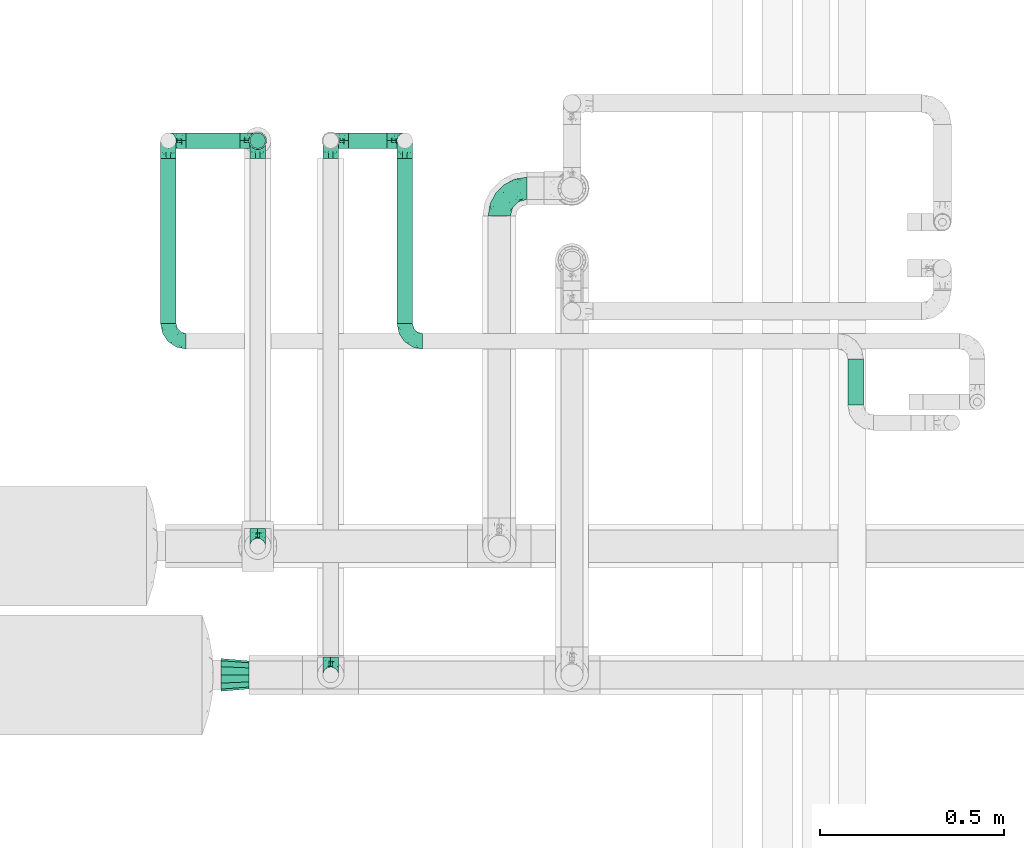
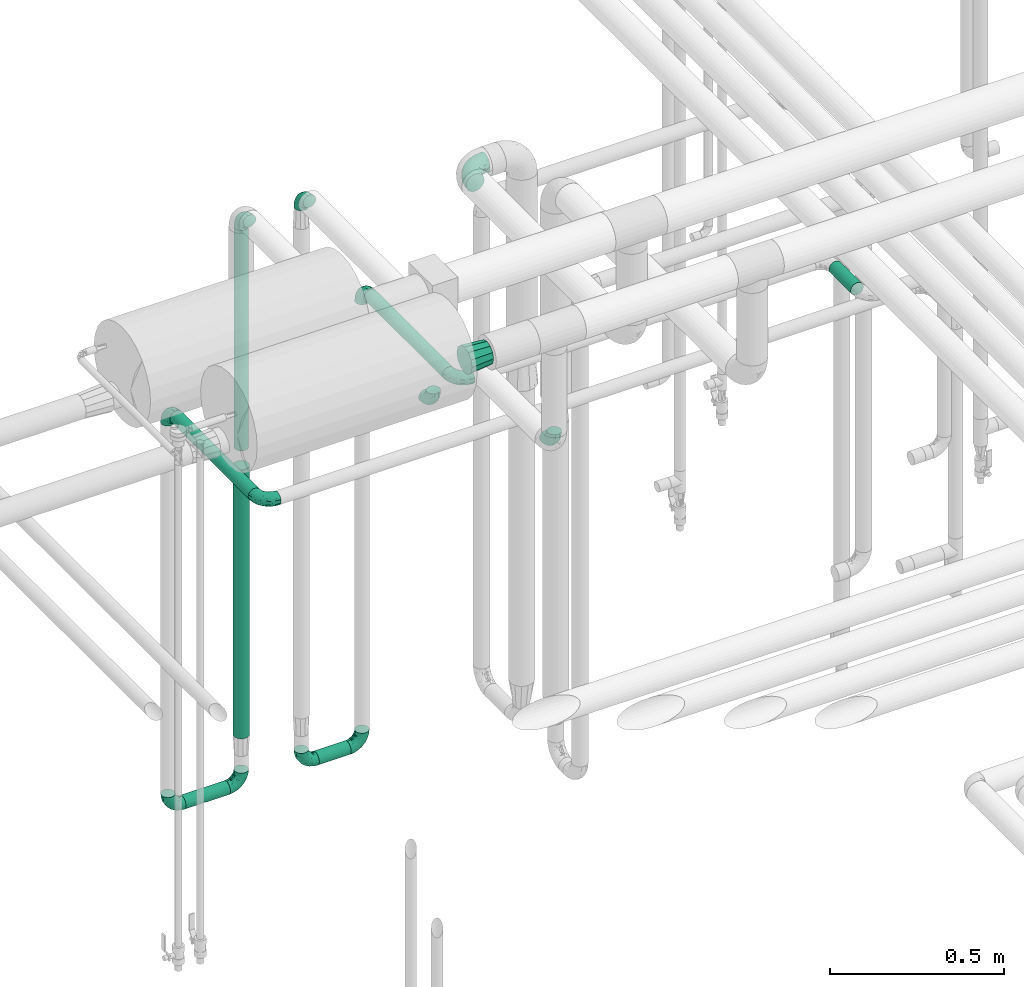
# One storey, part 573 of 827: 14 flow fittings, 7 flow segments.
"""IFC2X3 building model written with IfcOpenShell, lengths in millimetres."""

from ifc_helpers import new_model, entity, si_unit, converted_unit, derived_unit, direction, frame, origin, origin_2d_with_axis, place, context, subcontext, project, spatial, circle, extrude, faceted_brep, source, transform, mapped, material, type_object, type_shapes, element, save


model = new_model("IFC2X3")

# Units and contexts
model_context = context("Model", 3, precision=0.01, world=origin(), true_north=direction((6.12303176911189e-17, 1.0)))
body_context = subcontext(model_context, "Body", "Model", "MODEL_VIEW")
ifc_project = project(units=[si_unit("LENGTHUNIT", "METRE", prefix="MILLI"), si_unit("AREAUNIT", "SQUARE_METRE"), si_unit("VOLUMEUNIT", "CUBIC_METRE"), converted_unit("PLANEANGLEUNIT", "DEGREE", entity("IfcRatioMeasure", 0.0174532925199433), si_unit("PLANEANGLEUNIT", "RADIAN"), dimensions=[0, 0, 0, 0, 0, 0, 0]), si_unit("MASSUNIT", "GRAM", prefix="KILO"), derived_unit("MASSDENSITYUNIT", [(si_unit("MASSUNIT", "GRAM", prefix="KILO"), 1), (si_unit("LENGTHUNIT", "METRE"), -3)]), derived_unit("MOMENTOFINERTIAUNIT", [(si_unit("LENGTHUNIT", "METRE"), 4)]), si_unit("TIMEUNIT", "SECOND"), si_unit("FREQUENCYUNIT", "HERTZ"), si_unit("THERMODYNAMICTEMPERATUREUNIT", "DEGREE_CELSIUS"), derived_unit("THERMALTRANSMITTANCEUNIT", [(si_unit("MASSUNIT", "GRAM", prefix="KILO"), 1), (si_unit("THERMODYNAMICTEMPERATUREUNIT", "KELVIN"), -1), (si_unit("TIMEUNIT", "SECOND"), -3)]), derived_unit("VOLUMETRICFLOWRATEUNIT", [(si_unit("LENGTHUNIT", "METRE"), 3), (si_unit("TIMEUNIT", "SECOND"), -1)]), derived_unit("MASSFLOWRATEUNIT", [(si_unit("MASSUNIT", "GRAM", prefix="KILO"), 1), (si_unit("TIMEUNIT", "SECOND"), -1)]), derived_unit("ROTATIONALFREQUENCYUNIT", [(si_unit("TIMEUNIT", "SECOND"), -1)]), si_unit("ELECTRICCURRENTUNIT", "AMPERE"), si_unit("ELECTRICVOLTAGEUNIT", "VOLT"), si_unit("POWERUNIT", "WATT"), si_unit("FORCEUNIT", "NEWTON", prefix="KILO"), si_unit("ILLUMINANCEUNIT", "LUX"), si_unit("LUMINOUSFLUXUNIT", "LUMEN"), si_unit("LUMINOUSINTENSITYUNIT", "CANDELA"), derived_unit("USERDEFINED", [(si_unit("MASSUNIT", "GRAM", prefix="KILO"), -1), (si_unit("LENGTHUNIT", "METRE"), -2), (si_unit("TIMEUNIT", "SECOND"), 3), (si_unit("LUMINOUSFLUXUNIT", "LUMEN"), 1)]), derived_unit("LINEARVELOCITYUNIT", [(si_unit("LENGTHUNIT", "METRE"), 1), (si_unit("TIMEUNIT", "SECOND"), -1)]), si_unit("PRESSUREUNIT", "PASCAL"), derived_unit("USERDEFINED", [(si_unit("LENGTHUNIT", "METRE"), -2), (si_unit("MASSUNIT", "GRAM", prefix="KILO"), 1), (si_unit("TIMEUNIT", "SECOND"), -2)]), derived_unit("LINEARFORCEUNIT", [(si_unit("MASSUNIT", "GRAM", prefix="KILO"), 1), (si_unit("LENGTHUNIT", "METRE"), 1), (si_unit("TIMEUNIT", "SECOND"), -2), (si_unit("LENGTHUNIT", "METRE"), -1)]), derived_unit("PLANARFORCEUNIT", [(si_unit("MASSUNIT", "GRAM", prefix="KILO"), 1), (si_unit("LENGTHUNIT", "METRE"), 1), (si_unit("TIMEUNIT", "SECOND"), -2), (si_unit("LENGTHUNIT", "METRE"), -2)])], contexts=[model_context])

# Site, building, storey
site_placement = place(None, origin())
site = spatial("IfcSite", under=ifc_project, at=site_placement, CompositionType="ELEMENT")
building_placement = place(site_placement, origin())
building = spatial("IfcBuilding", under=site, at=building_placement, CompositionType="ELEMENT")
storey_placement = place(building_placement, frame((0.0, 0.0, 28200.0)))
storey = spatial("IfcBuildingStorey", under=building, at=storey_placement, Name="08", CompositionType="ELEMENT", Elevation=28200.0)

# Flow segments
pipe_segment_type = type_object("IfcPipeSegmentType", PredefinedType="NOTDEFINED")
flow_segment_1_placement = place(storey_placement, frame((17314.71, 15829.04, 381.11)))
element("IfcFlowSegment", 1, at=flow_segment_1_placement, inside=storey, type_object=pipe_segment_type, context=body_context, shape_type="SweptSolid", body=[
    extrude(circle(Radius=21.15, at=origin_2d_with_axis()), frame((0.0, 22.75, 22.75), z_axis=(1.0, 0.0, 0.0), x_axis=(0.0, -1.0, 0.0)), (0.0, 0.0, 1.0), 105.488840849872),
])
flow_segment_2_placement = place(storey_placement, frame((16873.63, 15829.04, 381.19)))
element("IfcFlowSegment", 2, at=flow_segment_2_placement, inside=storey, type_object=pipe_segment_type, context=body_context, shape_type="SweptSolid", body=[
    extrude(circle(Radius=21.15, at=origin_2d_with_axis()), frame((0.0, 22.75, 22.75), z_axis=(1.0, 0.0, 0.0), x_axis=(0.0, -1.0, 0.0)), (0.0, 0.0, 1.0), 146.73003738029),
])
flow_segment_3_placement = place(storey_placement, frame((18670.46, 15133.74, 1977.25)))
element("IfcFlowSegment", 3, at=flow_segment_3_placement, inside=storey, type_object=pipe_segment_type, context=body_context, shape_type="SweptSolid", body=[
    extrude(circle(Radius=21.15, at=origin_2d_with_axis()), frame((22.75, 0.0, 22.75), z_axis=(0.0, 1.0, 0.0), x_axis=(-1.0, 0.0, 0.0)), (0.0, 0.0, 1.0), 125.041289846792),
])
flow_segment_4_placement = place(storey_placement, frame((17045.62, 15829.04, 1580.0)))
element("IfcFlowSegment", 4, at=flow_segment_4_placement, inside=storey, type_object=pipe_segment_type, context=body_context, shape_type="SweptSolid", body=[
    extrude(circle(Radius=21.15, at=origin_2d_with_axis()), frame((22.75, 22.75, 0.0)), (0.0, 0.0, 1.0), 772.000000000002),
])
flow_segment_5_placement = place(storey_placement, frame((17042.77, 15826.19, 574.2)))
element("IfcFlowSegment", 5, at=flow_segment_5_placement, inside=storey, type_object=pipe_segment_type, context=body_context, shape_type="SweptSolid", body=[
    extrude(circle(Radius=24.0, at=origin_2d_with_axis()), frame((25.6, 25.6, 0.0)), (0.0, 0.0, 1.0), 941.79999999999),
])
flow_segment_6_placement = place(storey_placement, frame((17445.46, 15354.79, 1977.25)))
element("IfcFlowSegment", 6, at=flow_segment_6_placement, inside=storey, type_object=pipe_segment_type, context=body_context, shape_type="SweptSolid", body=[
    extrude(circle(Radius=21.15, at=origin_2d_with_axis()), frame((22.75, 0.0, 22.75), z_axis=(0.0, 1.0, 0.0), x_axis=(1.0, 0.0, 0.0)), (0.0, 0.0, 1.0), 448.999348960777),
])
flow_segment_7_placement = place(storey_placement, frame((16802.89, 15354.79, 1777.25)))
element("IfcFlowSegment", 7, at=flow_segment_7_placement, inside=storey, type_object=pipe_segment_type, context=body_context, shape_type="SweptSolid", body=[
    extrude(circle(Radius=21.15, at=origin_2d_with_axis()), frame((22.75, 0.0, 22.75), z_axis=(0.0, 1.0, 0.0), x_axis=(1.0, 0.0, 0.0)), (0.0, 0.0, 1.0), 448.999348960775),
])

# Flow fittings
ifc_material = material()
pipe_fitting_type_1 = type_object("IfcPipeFittingType", Name="ADSK_1", PredefinedType="NOTDEFINED", material=ifc_material)
shared_shape_1 = source(origin(), body_context, "Body", "Brep", [
    faceted_brep([(-48.0, 10.6, -18.36), (-48.0, 5.49, -20.48), (-48.0, 0.0, -21.2), (-48.0, -5.49, -20.48), (-48.0, -10.6, -18.36), (-48.0, -14.99, -14.99), (-48.0, -18.36, -10.6), (-48.0, -20.48, -5.49), (-48.0, -21.2, 0.0), (-48.0, -20.48, 5.49), (-48.0, -18.36, 10.6), (-48.0, -14.99, 14.99), (-48.0, -10.6, 18.36), (-48.0, -5.49, 20.48), (-48.0, 0.0, 21.2), (-48.0, 5.49, 20.48), (-48.0, 10.6, 18.36), (-48.0, 14.99, 14.99), (-48.0, 18.36, 10.6), (-48.0, 20.48, 5.49), (-48.0, 21.2, 0.0), (-48.0, 20.48, -5.49), (-48.0, 18.36, -10.6), (-48.0, 14.99, -14.99), (0.0, 48.0, -21.2), (-5.49, 48.0, -20.48), (-10.6, 48.0, -18.36), (-14.99, 48.0, -14.99), (-18.36, 48.0, -10.6), (-20.48, 48.0, -5.49), (-21.2, 48.0, 0.0), (-20.48, 48.0, 5.49), (-18.36, 48.0, 10.6), (-14.99, 48.0, 14.99), (-10.6, 48.0, 18.36), (-5.49, 48.0, 20.48), (0.0, 48.0, 21.2), (5.49, 48.0, 20.48), (10.6, 48.0, 18.36), (14.99, 48.0, 14.99), (18.36, 48.0, 10.6), (20.48, 48.0, 5.49), (21.2, 48.0, 0.0), (20.48, 48.0, -5.49), (18.36, 48.0, -10.6), (14.99, 48.0, -14.99), (10.6, 48.0, -18.36), (5.49, 48.0, -20.48), (-35.25, -16.22, 12.01), (-34.76, -18.57, 0.0), (-20.87, -12.37, 10.9), (-31.49, -11.78, 15.9), (-37.0, -2.58, 20.86), (-33.89, 3.62, 21.15), (-31.81, -18.14, 6.76), (-5.78, 5.78, 17.67), (-19.42, -4.1, 17.86), (-9.6, -3.39, 13.73), (-35.44, -7.73, 19.13), (11.78, 31.49, 15.9), (-5.93, -5.46, 6.95), (-18.45, -13.78, 5.46), (-10.29, -8.43, 0.0), (-24.6, 0.55, 20.62), (-37.28, 17.94, 13.81), (-33.38, 22.85, 9.59), (-41.46, 20.06, 8.75), (-29.51, 20.45, 15.16), (-15.04, 10.79, 21.13), (-7.08, 16.98, 20.93), (-8.39, 23.51, 21.15), (-40.86, 13.03, 17.26), (-8.05, 41.26, 19.83), (-3.21, 35.97, 21.14), (8.53, 19.66, 14.74), (4.1, 19.42, 17.86), (-37.72, 22.66, 4.78), (-37.07, 8.58, 19.98), (-13.0, 5.43, 19.97), (-3.78, 13.93, 19.7), (3.02, 8.69, 13.43), (-2.27, -0.05, 10.65), (6.22, 6.99, 7.09), (-22.25, 34.6, 9.45), (18.14, 31.81, 6.76), (16.22, 35.25, 12.01), (12.37, 20.87, 10.9), (7.73, 35.44, 19.13), (-21.52, -15.93, 0.0), (2.58, 37.0, 20.86), (18.57, 34.76, 0.0), (13.78, 18.45, 5.46), (15.93, 21.52, 0.0), (-20.03, -8.54, 14.9), (-28.6, 28.6, 5.16), (-24.79, 34.6, 0.0), (-34.6, 24.79, 0.0), (-22.81, 37.41, 4.68), (-23.36, 26.33, 14.79), (-13.68, 37.05, 17.49), (-17.72, 38.12, 13.73), (-26.25, 27.3, 11.24), (-9.71, 32.34, 20.14), (-17.26, 25.6, 18.71), (-26.33, 9.99, 20.77), (-24.06, 6.05, 21.2), (-25.02, 15.46, 19.56), (-24.3, 20.72, 17.57), (-31.95, 15.23, 17.8), (-13.53, 24.7, 20.21), (-17.6, 17.6, 20.6), (-0.55, 24.6, 20.62), (-11.41, -7.48, 10.43), (0.93, -0.93, 0.0), (8.43, 10.29, 0.0), (-11.41, -7.48, -10.43), (-20.1, -8.84, -14.66), (-9.6, -3.39, -13.73), (7.73, 35.44, -19.13), (4.1, 19.42, -17.86), (-0.55, 24.6, -20.62), (-38.12, 17.72, -13.73), (-37.05, 13.68, -17.49), (-32.34, 9.71, -20.14), (-41.26, 8.05, -19.83), (-37.41, 22.81, -4.68), (-23.51, 8.39, -21.15), (-35.97, 3.21, -21.14), (-28.6, 28.6, -5.16), (-31.81, -18.14, -6.76), (-18.45, -13.78, -5.46), (-25.6, 17.26, -18.71), (-19.42, -4.1, -17.86), (-17.94, 37.28, -13.81), (-22.85, 33.38, -9.59), (-20.06, 41.46, -8.75), (-31.49, -11.78, -15.9), (-35.25, -16.22, -12.01), (8.53, 19.66, -14.74), (11.78, 31.49, -15.9), (-9.99, 26.33, -20.77), (-6.05, 24.06, -21.2), (-10.79, 15.04, -21.13), (-37.0, -2.58, -20.86), (-16.98, 7.08, -20.93), (-5.43, 13.0, -19.97), (-13.93, 3.78, -19.7), (-20.87, -12.37, -10.9), (-26.33, 23.36, -14.79), (-22.66, 37.72, -4.78), (13.78, 18.45, -5.46), (18.14, 31.81, -6.76), (-15.46, 25.02, -19.56), (-20.72, 24.3, -17.57), (16.22, 35.25, -12.01), (-13.03, 40.86, -17.26), (-8.58, 37.07, -19.98), (2.58, 37.0, -20.86), (-3.62, 33.89, -21.15), (-34.6, 22.25, -9.45), (6.22, 6.99, -7.09), (-20.45, 29.51, -15.16), (-35.44, -7.73, -19.13), (12.37, 20.87, -10.9), (-27.3, 26.25, -11.24), (-15.23, 31.95, -17.8), (-24.7, 13.53, -20.21), (-24.6, 0.55, -20.62), (-5.78, 5.78, -17.67), (-17.6, 17.6, -20.6), (3.02, 8.69, -13.43), (-5.93, -5.46, -6.95), (-2.27, -0.05, -10.65)], [[[0, 1, 2, 3, 4, 5, 6, 7, 8, 9, 10, 11, 12, 13, 14, 15, 16, 17, 18, 19, 20, 21, 22, 23]], [[24, 25, 26, 27, 28, 29, 30, 31, 32, 33, 34, 35, 36, 37, 38, 39, 40, 41, 42, 43, 44, 45, 46, 47]], [[10, 48, 11]], [[9, 8, 49]], [[48, 50, 51]], [[14, 52, 53]], [[10, 54, 48]], [[9, 54, 10]], [[55, 56, 57]], [[51, 12, 11]], [[51, 58, 12]], [[59, 39, 38]], [[60, 61, 62]], [[58, 56, 63]], [[64, 65, 66]], [[67, 65, 64]], [[68, 69, 70]], [[16, 71, 17]], [[13, 52, 14]], [[35, 72, 73]], [[14, 53, 15]], [[17, 64, 18]], [[74, 59, 75]], [[20, 19, 76]], [[66, 19, 18]], [[77, 15, 53]], [[15, 77, 16]], [[69, 78, 79]], [[80, 81, 82]], [[32, 31, 83]], [[84, 85, 86]], [[59, 87, 75]], [[61, 54, 88]], [[36, 89, 37]], [[84, 41, 40]], [[36, 35, 73]], [[90, 41, 84]], [[40, 39, 85]], [[12, 58, 13]], [[85, 84, 40]], [[91, 84, 86]], [[84, 92, 90]], [[87, 38, 37]], [[93, 56, 51]], [[65, 94, 76]], [[94, 95, 96]], [[84, 91, 92]], [[95, 97, 30]], [[98, 99, 100]], [[76, 94, 96]], [[101, 98, 83]], [[100, 99, 33]], [[102, 70, 73]], [[103, 102, 99]], [[94, 97, 95]], [[72, 99, 102]], [[72, 35, 34]], [[34, 33, 99]], [[9, 49, 54]], [[87, 59, 38]], [[104, 105, 68]], [[106, 103, 107]], [[106, 77, 104]], [[71, 64, 17]], [[108, 107, 67]], [[33, 32, 100]], [[109, 103, 110]], [[102, 109, 70]], [[89, 73, 111]], [[50, 48, 54]], [[51, 11, 48]], [[56, 58, 51]], [[88, 54, 49]], [[52, 58, 63]], [[50, 112, 93]], [[56, 55, 78]], [[39, 59, 85]], [[86, 85, 59]], [[89, 87, 37]], [[42, 41, 90]], [[111, 79, 75]], [[111, 75, 87]], [[75, 55, 80]], [[104, 77, 53]], [[71, 77, 108]], [[32, 83, 100]], [[98, 100, 83]], [[99, 98, 103]], [[106, 107, 108]], [[68, 70, 110]], [[111, 73, 70]], [[68, 110, 104]], [[68, 63, 78]], [[57, 93, 112]], [[80, 55, 57]], [[61, 50, 54]], [[80, 82, 86]], [[81, 57, 112]], [[74, 86, 59]], [[60, 113, 82]], [[82, 114, 91]], [[101, 94, 65]], [[97, 94, 83]], [[73, 89, 36]], [[87, 89, 111]], [[58, 52, 13]], [[53, 52, 63]], [[104, 53, 105]], [[106, 104, 110]], [[20, 76, 96]], [[76, 19, 66]], [[103, 106, 110]], [[77, 106, 108]], [[103, 98, 107]], [[67, 107, 98]], [[67, 98, 101]], [[108, 67, 64]], [[53, 63, 105]], [[63, 68, 105]], [[83, 31, 97]], [[30, 97, 31]], [[62, 113, 60]], [[112, 61, 60]], [[61, 88, 62]], [[86, 82, 91]], [[56, 78, 63]], [[114, 82, 113]], [[114, 92, 91]], [[79, 78, 55]], [[75, 79, 55]], [[69, 79, 111]], [[70, 69, 111]], [[78, 69, 68]], [[77, 71, 16]], [[64, 71, 108]], [[64, 66, 18]], [[76, 66, 65]], [[99, 72, 34]], [[73, 72, 102]], [[94, 101, 83]], [[67, 101, 65]], [[75, 80, 74]], [[80, 86, 74]], [[70, 109, 110]], [[102, 103, 109]], [[50, 93, 51]], [[57, 56, 93]], [[61, 112, 50]], [[81, 112, 60]], [[82, 81, 60]], [[80, 57, 81]], [[115, 116, 117]], [[118, 119, 120]], [[121, 122, 23]], [[123, 124, 122]], [[96, 125, 20]], [[123, 126, 127]], [[128, 96, 95]], [[129, 130, 88]], [[123, 122, 131]], [[116, 132, 117]], [[133, 134, 135]], [[0, 124, 1]], [[5, 136, 137]], [[138, 119, 139]], [[129, 88, 49]], [[140, 141, 142]], [[6, 5, 137]], [[46, 118, 47]], [[143, 3, 2]], [[144, 145, 146]], [[6, 129, 7]], [[129, 137, 147]], [[127, 2, 1]], [[148, 122, 121]], [[128, 125, 96]], [[134, 128, 149]], [[95, 149, 128]], [[150, 151, 92]], [[30, 29, 149]], [[152, 131, 153]], [[27, 133, 28]], [[154, 45, 44]], [[136, 5, 4]], [[27, 26, 155]], [[156, 26, 25]], [[24, 157, 158]], [[24, 47, 157]], [[22, 21, 159]], [[160, 150, 114]], [[134, 133, 161]], [[142, 144, 126]], [[46, 139, 118]], [[162, 136, 4]], [[156, 25, 158]], [[1, 124, 127]], [[115, 147, 116]], [[45, 154, 139]], [[139, 46, 45]], [[154, 163, 139]], [[162, 4, 3]], [[42, 90, 43]], [[130, 129, 147]], [[49, 7, 129]], [[43, 151, 44]], [[0, 23, 122]], [[24, 158, 25]], [[136, 162, 132]], [[135, 29, 28]], [[43, 90, 151]], [[164, 148, 159]], [[152, 156, 140]], [[155, 133, 27]], [[165, 153, 161]], [[23, 22, 121]], [[123, 131, 166]], [[123, 166, 126]], [[143, 127, 167]], [[147, 137, 136]], [[8, 7, 49]], [[129, 6, 137]], [[143, 162, 3]], [[167, 146, 132]], [[167, 132, 162]], [[132, 168, 117]], [[44, 151, 154]], [[92, 151, 90]], [[163, 154, 151]], [[119, 118, 139]], [[157, 118, 120]], [[138, 139, 163]], [[119, 168, 145]], [[140, 156, 158]], [[155, 156, 165]], [[22, 159, 121]], [[148, 121, 159]], [[122, 148, 131]], [[152, 153, 165]], [[142, 126, 169]], [[167, 127, 126]], [[142, 169, 140]], [[142, 120, 145]], [[168, 170, 117]], [[160, 171, 172]], [[115, 172, 171]], [[171, 62, 130]], [[119, 170, 168]], [[170, 163, 160]], [[150, 163, 151]], [[113, 171, 160]], [[164, 128, 134]], [[125, 128, 159]], [[127, 143, 2]], [[162, 143, 167]], [[118, 157, 47]], [[158, 157, 120]], [[140, 158, 141]], [[152, 140, 169]], [[30, 149, 95]], [[149, 29, 135]], [[131, 152, 169]], [[156, 152, 165]], [[131, 148, 153]], [[161, 153, 148]], [[161, 148, 164]], [[165, 161, 133]], [[158, 120, 141]], [[120, 142, 141]], [[159, 21, 125]], [[20, 125, 21]], [[115, 130, 147]], [[114, 113, 160]], [[62, 171, 113]], [[62, 88, 130]], [[160, 163, 150]], [[150, 92, 114]], [[119, 145, 120]], [[146, 145, 168]], [[132, 146, 168]], [[144, 146, 167]], [[126, 144, 167]], [[145, 144, 142]], [[156, 155, 26]], [[133, 155, 165]], [[133, 135, 28]], [[149, 135, 134]], [[122, 124, 0]], [[127, 124, 123]], [[128, 164, 159]], [[161, 164, 134]], [[163, 170, 138]], [[170, 119, 138]], [[131, 169, 166]], [[126, 166, 169]], [[147, 136, 116]], [[132, 116, 136]], [[172, 115, 117]], [[130, 115, 171]], [[117, 170, 172]], [[160, 172, 170]]]),
])
type_shapes(pipe_fitting_type_1, [shared_shape_1])
for number, where, z_axis, x_axis, name in (
    (8, (17068.36, 15851.79, 403.94), (0.0, -1.0, 0.0), (1.0, 0.0, 0.0), "ADSK_1"),
    (9, (17266.71, 15851.79, 403.86), (0.0, 1.0, 0.0), (-1.0, 0.0, 0.0), "ADSK_1"),
    (10, (16825.63, 15851.79, 403.94), (0.0, 1.0, 0.0), (-1.0, 0.0, 0.0), "ADSK_1"),
    (11, (17468.2, 15851.79, 403.86), (0.0, -1.0, 0.0), (1.0, 0.0, 0.0), "ADSK_1"),
    (12, (17068.36, 15851.79, 2400.0), (1.0, 0.0, 0.0), (0.0, 0.0, 1.0), "ADSK_1"),
    (13, (17068.36, 14749.79, 2400.0), (1.0, 0.0, 0.0), (0.0, 0.0, -1.0), "ADSK_1"),
    (14, (17266.71, 14400.0, 2400.0), (1.0, 0.0, 0.0), (0.0, 0.0, -1.0), "ADSK_1"),
    (15, (17266.71, 15851.79, 2400.0), (1.0, 0.0, 0.0), (0.0, 0.0, 1.0), "ADSK_1"),
    (16, (17468.2, 15306.79, 2000.0), (0.0, 0.0, 1.0), (0.0, -1.0, 0.0), "ADSK_1"),
    (17, (17468.2, 15851.79, 2000.0), (1.0, 0.0, 0.0), (0.0, 0.0, 1.0), "ADSK_1"),
    (18, (16825.63, 15306.79, 1800.0), (0.0, 0.0, 1.0), (0.0, -1.0, 0.0), "ADSK_1"),
    (19, (16825.63, 15851.79, 1800.0), (1.0, 0.0, 0.0), (0.0, 0.0, 1.0), "ADSK_1"),
):
    element("IfcFlowFitting", number, at=place(storey_placement, frame(where, z_axis=z_axis, x_axis=x_axis)), inside=storey, type_object=pipe_fitting_type_1, material=ifc_material, Name=name, ObjectType="ADSK_1", context=body_context, shape_type="MappedRepresentation", body=[
        mapped(shared_shape_1, transform((0.0, 0.0, 0.0), scale=1.0)),
    ])
pipe_fitting_type_2 = type_object("IfcPipeFittingType", Name="ADSK_1", PredefinedType="NOTDEFINED", material=ifc_material)
shared_shape_2 = source(origin(), body_context, "Body", "Brep", [
    faceted_brep([(-76.0, 15.07, -26.11), (-76.0, 7.8, -29.12), (-76.0, 0.0, -30.15), (-76.0, -7.8, -29.12), (-76.0, -15.08, -26.11), (-76.0, -21.32, -21.32), (-76.0, -26.11, -15.08), (-76.0, -29.12, -7.8), (-76.0, -30.15, 0.0), (-76.0, -29.12, 7.8), (-76.0, -26.11, 15.07), (-76.0, -21.32, 21.32), (-76.0, -15.08, 26.11), (-76.0, -7.8, 29.12), (-76.0, 0.0, 30.15), (-76.0, 7.8, 29.12), (-76.0, 15.07, 26.11), (-76.0, 21.32, 21.32), (-76.0, 26.11, 15.07), (-76.0, 29.12, 7.8), (-76.0, 30.15, 0.0), (-76.0, 29.12, -7.8), (-76.0, 26.11, -15.08), (-76.0, 21.32, -21.32), (0.0, 76.0, -30.15), (-7.8, 76.0, -29.12), (-15.07, 76.0, -26.11), (-21.32, 76.0, -21.32), (-26.11, 76.0, -15.08), (-29.12, 76.0, -7.8), (-30.15, 76.0, 0.0), (-29.12, 76.0, 7.8), (-26.11, 76.0, 15.07), (-21.32, 76.0, 21.32), (-15.07, 76.0, 26.11), (-7.8, 76.0, 29.12), (0.0, 76.0, 30.15), (7.8, 76.0, 29.12), (15.08, 76.0, 26.11), (21.32, 76.0, 21.32), (26.11, 76.0, 15.07), (29.12, 76.0, 7.8), (30.15, 76.0, 0.0), (29.12, 76.0, -7.8), (26.11, 76.0, -15.08), (21.32, 76.0, -21.32), (15.08, 76.0, -26.11), (7.8, 76.0, -29.12), (10.79, 31.43, 21.07), (4.32, 31.7, 25.72), (1.65, 15.19, 19.92), (-61.17, -27.8, 0.0), (-51.1, -25.49, 9.84), (-56.14, -10.61, 27.27), (-31.7, -4.32, 25.72), (-39.75, 1.72, 29.41), (-43.2, -24.95, 0.0), (-1.86, 1.86, 0.0), (4.49, 7.65, 5.78), (-7.82, -4.61, 5.83), (-56.21, -22.79, 17.21), (-58.98, -3.38, 29.7), (-53.96, 5.6, 30.07), (-10.86, 10.86, 25.48), (-17.2, -2.6, 20.44), (-49.15, -16.01, 22.7), (-22.18, -14.24, 7.99), (-28.4, -17.42, 0.0), (-13.61, -9.88, 0.0), (-39.0, 23.48, 27.76), (-58.76, 12.54, 28.36), (-41.61, 15.41, 29.48), (16.01, 49.15, 22.7), (-58.55, 25.93, 19.53), (-51.53, 33.5, 13.51), (-64.92, 28.76, 12.4), (-7.48, 23.14, 28.25), (-1.72, 39.75, 29.41), (-12.04, 27.88, 29.88), (-63.91, 18.81, 24.52), (-11.63, 65.16, 28.18), (-4.97, 57.02, 30.05), (9.88, 13.61, 0.0), (-62.5, 31.74, 5.02), (-45.17, 30.98, 21.2), (-21.78, 9.76, 28.58), (10.61, 56.14, 27.27), (-32.09, 54.42, 13.26), (22.79, 56.21, 17.21), (15.38, 31.17, 15.63), (25.49, 51.1, 9.84), (21.84, 36.35, 5.92), (24.95, 43.2, 0.0), (3.38, 58.98, 29.7), (-31.17, -15.38, 15.63), (-39.39, 41.78, 15.45), (-34.56, 41.13, 20.79), (-39.81, -23.25, 5.49), (27.8, 61.17, 0.0), (-31.74, 62.5, 5.02), (-53.07, 36.29, 0.0), (-42.95, 42.95, 7.29), (-36.29, 53.07, 0.0), (-19.83, 58.51, 24.79), (-25.48, 60.2, 19.41), (-14.53, 50.96, 28.57), (-13.31, 37.09, 30.07), (-26.16, 40.06, 26.4), (-32.43, -10.35, 21.9), (17.42, 28.4, 0.0), (14.24, 22.18, 7.99), (-38.67, 9.72, 30.15), (-24.66, 17.36, 30.09), (-37.08, 31.49, 24.99), (-49.27, 22.83, 25.24), (-20.8, 38.81, 28.63), (-27.58, 27.58, 29.2), (-36.07, -20.23, 10.71), (-15.19, -6.16, 14.9), (6.6, 15.4, 14.49), (-2.51, 2.51, 11.35), (-65.16, 11.63, -28.18), (-49.15, -16.01, -22.7), (-57.02, 4.97, -30.05), (-25.93, 58.55, -19.53), (-33.5, 51.53, -13.51), (-28.76, 64.92, -12.4), (-60.2, 25.48, -19.41), (-58.51, 19.83, -24.79), (4.61, 7.82, -5.83), (-7.65, -4.49, -5.78), (-2.51, 2.51, -11.35), (-62.5, 31.74, -5.02), (-50.96, 14.53, -28.57), (-37.09, 13.31, -30.07), (-42.95, 42.95, -7.29), (25.49, 51.1, -9.84), (22.79, 56.21, -17.21), (-40.06, 26.16, -26.4), (3.38, 58.98, -29.7), (-5.6, 53.96, -30.07), (-27.88, 12.04, -29.88), (-9.76, 21.78, -28.58), (-23.14, 7.48, -28.25), (-51.1, -25.49, -9.84), (15.38, 31.17, -15.63), (16.01, 49.15, -22.7), (-23.48, 39.0, -27.76), (-12.54, 58.76, -28.36), (-15.41, 41.61, -29.48), (-56.21, -22.79, -17.21), (-9.72, 38.67, -30.15), (-17.36, 24.66, -30.09), (-22.18, -14.24, -7.99), (-41.13, 34.56, -20.79), (-31.74, 62.5, -5.02), (-58.98, -3.38, -29.7), (-31.17, -15.38, -15.63), (-56.14, -10.61, -27.27), (14.24, 22.18, -7.99), (23.25, 39.81, -5.49), (-31.49, 37.08, -24.99), (-15.19, -6.16, -14.9), (1.65, 15.19, -19.92), (-18.81, 63.91, -24.52), (-32.59, -11.62, -20.84), (-31.7, -4.32, -25.72), (-17.2, -2.6, -20.44), (-39.75, 1.72, -29.41), (-54.42, 32.09, -13.26), (-30.98, 45.17, -21.2), (10.61, 56.14, -27.27), (10.23, 31.31, -21.52), (4.32, 31.7, -25.72), (-41.78, 39.39, -15.45), (-1.72, 39.75, -29.41), (-36.35, -21.84, -5.92), (-22.83, 49.27, -25.24), (-38.81, 20.8, -28.63), (-27.58, 27.58, -29.2), (-10.86, 10.86, -25.48), (20.23, 36.07, -10.71), (6.6, 15.4, -14.49)], [[[0, 1, 2, 3, 4, 5, 6, 7, 8, 9, 10, 11, 12, 13, 14, 15, 16, 17, 18, 19, 20, 21, 22, 23]], [[24, 25, 26, 27, 28, 29, 30, 31, 32, 33, 34, 35, 36, 37, 38, 39, 40, 41, 42, 43, 44, 45, 46, 47]], [[48, 49, 50]], [[51, 52, 9]], [[53, 54, 55]], [[9, 52, 10]], [[56, 52, 51]], [[57, 58, 59]], [[11, 10, 60]], [[14, 61, 62]], [[63, 54, 64]], [[65, 12, 11]], [[65, 53, 12]], [[66, 67, 68]], [[69, 70, 71]], [[72, 39, 38]], [[73, 74, 75]], [[15, 70, 16]], [[76, 77, 78]], [[16, 79, 17]], [[13, 61, 14]], [[35, 80, 81]], [[14, 62, 15]], [[17, 73, 18]], [[57, 82, 58]], [[20, 19, 83]], [[75, 19, 18]], [[70, 15, 62]], [[73, 84, 74]], [[78, 85, 76]], [[38, 86, 72]], [[32, 31, 87]], [[88, 89, 90]], [[91, 92, 90]], [[72, 86, 49]], [[36, 93, 37]], [[75, 83, 19]], [[36, 35, 81]], [[60, 94, 65]], [[40, 90, 41]], [[95, 96, 87]], [[88, 90, 40]], [[66, 97, 67]], [[90, 98, 41]], [[40, 39, 88]], [[99, 31, 30]], [[20, 83, 100]], [[101, 102, 100]], [[52, 60, 10]], [[102, 99, 30]], [[96, 103, 104]], [[83, 101, 100]], [[12, 53, 13]], [[104, 103, 33]], [[105, 106, 81]], [[107, 105, 103]], [[64, 54, 108]], [[80, 103, 105]], [[80, 35, 34]], [[34, 33, 103]], [[86, 38, 37]], [[109, 110, 82]], [[71, 111, 112]], [[69, 107, 113]], [[79, 73, 17]], [[114, 113, 84]], [[33, 32, 104]], [[115, 107, 116]], [[105, 115, 106]], [[93, 81, 77]], [[54, 53, 65]], [[61, 53, 55]], [[108, 94, 64]], [[54, 63, 85]], [[93, 86, 37]], [[77, 76, 49]], [[77, 49, 86]], [[49, 63, 50]], [[60, 52, 117]], [[65, 11, 60]], [[39, 72, 88]], [[89, 88, 72]], [[71, 70, 62]], [[79, 70, 114]], [[103, 96, 107]], [[69, 113, 114]], [[112, 106, 116]], [[77, 81, 106]], [[112, 116, 71]], [[112, 55, 85]], [[64, 50, 63]], [[57, 59, 68]], [[32, 87, 104]], [[96, 104, 87]], [[94, 118, 64]], [[50, 119, 89]], [[50, 64, 118]], [[50, 89, 48]], [[81, 93, 36]], [[86, 93, 77]], [[53, 61, 13]], [[62, 61, 55]], [[71, 62, 111]], [[69, 71, 116]], [[95, 101, 74]], [[99, 101, 87]], [[118, 66, 59]], [[117, 97, 66]], [[117, 66, 94]], [[91, 89, 110]], [[91, 110, 109]], [[110, 89, 119]], [[9, 8, 51]], [[98, 90, 92]], [[98, 42, 41]], [[101, 83, 74]], [[101, 99, 102]], [[87, 31, 99]], [[62, 55, 111]], [[55, 112, 111]], [[107, 69, 116]], [[70, 69, 114]], [[107, 96, 113]], [[84, 113, 96]], [[84, 96, 95]], [[114, 84, 73]], [[70, 79, 16]], [[73, 79, 114]], [[54, 85, 55]], [[76, 85, 63]], [[49, 76, 63]], [[77, 106, 78]], [[106, 112, 78]], [[85, 78, 112]], [[73, 75, 18]], [[83, 75, 74]], [[103, 80, 34]], [[81, 80, 105]], [[101, 95, 87]], [[84, 95, 74]], [[106, 115, 116]], [[105, 107, 115]], [[120, 59, 58]], [[82, 110, 58]], [[119, 58, 110]], [[118, 59, 120]], [[66, 68, 59]], [[54, 65, 108]], [[94, 108, 65]], [[66, 118, 94]], [[50, 118, 120]], [[50, 120, 119]], [[119, 120, 58]], [[89, 72, 48]], [[49, 48, 72]], [[60, 117, 94]], [[117, 52, 97]], [[52, 56, 97]], [[67, 97, 56]], [[92, 91, 109]], [[89, 91, 90]], [[121, 1, 0]], [[122, 5, 4]], [[2, 1, 123]], [[124, 125, 126]], [[127, 128, 23]], [[129, 130, 131]], [[100, 132, 20]], [[133, 134, 123]], [[135, 100, 102]], [[136, 137, 44]], [[133, 128, 138]], [[24, 139, 140]], [[141, 142, 143]], [[121, 128, 133]], [[6, 144, 7]], [[137, 145, 146]], [[144, 51, 7]], [[147, 148, 149]], [[144, 6, 150]], [[149, 151, 152]], [[153, 68, 67]], [[154, 128, 127]], [[30, 155, 102]], [[43, 42, 98]], [[156, 3, 2]], [[157, 144, 150]], [[158, 4, 3]], [[24, 140, 25]], [[155, 135, 102]], [[159, 160, 109]], [[30, 29, 155]], [[147, 138, 161]], [[27, 124, 28]], [[57, 129, 82]], [[162, 163, 131]], [[27, 26, 164]], [[148, 26, 25]], [[165, 166, 167]], [[24, 47, 139]], [[143, 168, 141]], [[22, 21, 169]], [[125, 124, 170]], [[148, 25, 140]], [[46, 146, 171]], [[158, 122, 4]], [[0, 23, 128]], [[1, 121, 123]], [[109, 82, 159]], [[45, 44, 137]], [[146, 46, 45]], [[136, 43, 98]], [[132, 21, 20]], [[136, 98, 92]], [[172, 173, 146]], [[46, 171, 47]], [[43, 136, 44]], [[174, 154, 169]], [[171, 173, 175]], [[6, 5, 150]], [[126, 29, 28]], [[176, 56, 144]], [[122, 158, 166]], [[164, 124, 27]], [[177, 161, 170]], [[23, 22, 127]], [[178, 138, 179]], [[133, 178, 134]], [[156, 123, 168]], [[156, 158, 3]], [[168, 143, 166]], [[168, 166, 158]], [[166, 180, 167]], [[173, 171, 146]], [[139, 171, 175]], [[172, 145, 163]], [[173, 180, 142]], [[5, 122, 150]], [[157, 150, 122]], [[137, 136, 181]], [[146, 45, 137]], [[149, 148, 140]], [[164, 148, 177]], [[128, 154, 138]], [[147, 161, 177]], [[152, 134, 179]], [[168, 123, 134]], [[152, 179, 149]], [[152, 175, 142]], [[57, 130, 129]], [[157, 165, 167]], [[22, 169, 127]], [[154, 127, 169]], [[163, 167, 180]], [[162, 157, 167]], [[173, 163, 180]], [[182, 163, 145]], [[123, 156, 2]], [[158, 156, 168]], [[171, 139, 47]], [[140, 139, 175]], [[149, 140, 151]], [[147, 149, 179]], [[174, 135, 125]], [[132, 135, 169]], [[176, 157, 153]], [[176, 153, 67]], [[153, 157, 162]], [[182, 159, 129]], [[181, 160, 159]], [[181, 159, 145]], [[51, 144, 56]], [[51, 8, 7]], [[135, 132, 100]], [[169, 21, 132]], [[126, 155, 29]], [[135, 155, 125]], [[140, 175, 151]], [[175, 152, 151]], [[138, 147, 179]], [[148, 147, 177]], [[138, 154, 161]], [[170, 161, 154]], [[170, 154, 174]], [[177, 170, 124]], [[148, 164, 26]], [[124, 164, 177]], [[173, 142, 175]], [[143, 142, 180]], [[166, 143, 180]], [[168, 134, 141]], [[134, 152, 141]], [[142, 141, 152]], [[124, 126, 28]], [[155, 126, 125]], [[128, 121, 0]], [[123, 121, 133]], [[135, 174, 169]], [[170, 174, 125]], [[134, 178, 179]], [[133, 138, 178]], [[130, 153, 162]], [[68, 153, 130]], [[57, 68, 130]], [[182, 129, 131]], [[159, 82, 129]], [[157, 122, 165]], [[166, 165, 122]], [[163, 162, 167]], [[162, 131, 130]], [[145, 172, 146]], [[163, 173, 172]], [[159, 182, 145]], [[131, 163, 182]], [[56, 176, 67]], [[157, 176, 144]], [[137, 181, 145]], [[181, 136, 160]], [[136, 92, 160]], [[109, 160, 92]]]),
])
type_shapes(pipe_fitting_type_2, [shared_shape_2])
flow_fitting_1_placement = place(storey_placement, frame((17724.74, 15722.44, 2400.16), z_axis=(0.0, -0.00205044073798272, 0.999997897844181), x_axis=(-1.0, 0.0, 0.0)))
element("IfcFlowFitting", 20, at=flow_fitting_1_placement, inside=storey, type_object=pipe_fitting_type_2, material=ifc_material, Name="ADSK_1", ObjectType="ADSK_1", context=body_context, shape_type="MappedRepresentation", body=[
    mapped(shared_shape_2, transform((0.0, 0.0, 0.0), scale=1.0)),
])
pipe_fitting_type_3 = type_object("IfcPipeFittingType", Name="ADSK_2", PredefinedType="NOTDEFINED", material=ifc_material)
shared_shape_3 = source(origin(), body_context, "Body", "Brep", [
    faceted_brep([(75.0, -44.5, 0.0), (75.0, -41.54, -11.05), (75.0, -38.54, -22.25), (75.0, -30.39, -30.39), (75.0, -22.25, -38.54), (75.0, -11.13, -41.52), (75.0, 0.0, -44.5), (75.0, 11.12, -41.52), (75.0, 22.25, -38.54), (75.0, 30.39, -30.39), (75.0, 38.54, -22.25), (75.0, 41.54, -11.05), (75.0, 44.5, 0.0), (75.0, 41.54, 11.05), (75.0, 38.54, 22.25), (75.0, 30.39, 30.39), (75.0, 22.25, 38.54), (75.0, 11.12, 41.52), (75.0, 0.0, 44.5), (75.0, -11.13, 41.52), (75.0, -22.25, 38.54), (75.0, -30.39, 30.39), (75.0, -38.54, 22.25), (75.0, -41.54, 11.05), (0.0, -32.91, -19.0), (0.0, -35.45, -9.5), (0.0, -38.0, 0.0), (0.0, -35.45, 9.5), (0.0, -32.91, 19.0), (0.0, -25.95, 25.95), (0.0, -19.0, 32.91), (0.0, -9.5, 35.45), (0.0, 0.0, 38.0), (0.0, 9.5, 35.45), (0.0, 19.0, 32.91), (0.0, 25.95, 25.95), (0.0, 32.91, 19.0), (0.0, 35.45, 9.5), (0.0, 38.0, 0.0), (0.0, 35.45, -9.5), (0.0, 32.91, -19.0), (0.0, 25.95, -25.95), (0.0, 19.0, -32.91), (0.0, 9.5, -35.45), (0.0, 0.0, -38.0), (0.0, -9.5, -35.45), (0.0, -19.0, -32.91), (0.0, -25.95, -25.95)], [[[0, 1, 2, 3, 4, 5, 6, 7, 8, 9, 10, 11, 12, 13, 14, 15, 16, 17, 18, 19, 20, 21, 22, 23]], [[24, 25, 26, 27, 28, 29, 30, 31, 32, 33, 34, 35, 36, 37, 38, 39, 40, 41, 42, 43, 44, 45, 46, 47]], [[24, 47, 46, 4, 3, 2]], [[42, 8, 7, 6, 44, 43]], [[10, 40, 39, 38, 12, 11]], [[44, 6, 5, 4, 46, 45]], [[2, 1, 0, 26, 25, 24]], [[9, 8, 42, 41, 40, 10]], [[36, 35, 34, 16, 15, 14]], [[30, 20, 19, 18, 32, 31]], [[22, 28, 27, 26, 0, 23]], [[32, 18, 17, 16, 34, 33]], [[14, 13, 12, 38, 37, 36]], [[21, 20, 30, 29, 28, 22]]]),
])
type_shapes(pipe_fitting_type_3, [shared_shape_3])
flow_fitting_2_placement = place(storey_placement, frame((17044.26, 14400.0, 2799.98), z_axis=(-0.000239364731064747, -5.1338117262291e-09, 0.999999971352262), x_axis=(-0.999999970970338, -2.76378034169475e-05, -0.000239364731115215)))
element("IfcFlowFitting", 21, at=flow_fitting_2_placement, inside=storey, type_object=pipe_fitting_type_3, material=ifc_material, Name="ADSK_2", ObjectType="ADSK_2", context=body_context, shape_type="MappedRepresentation", body=[
    mapped(shared_shape_3, transform((0.0, 0.0, 0.0), scale=1.0)),
])

save(model, "model.ifc")
